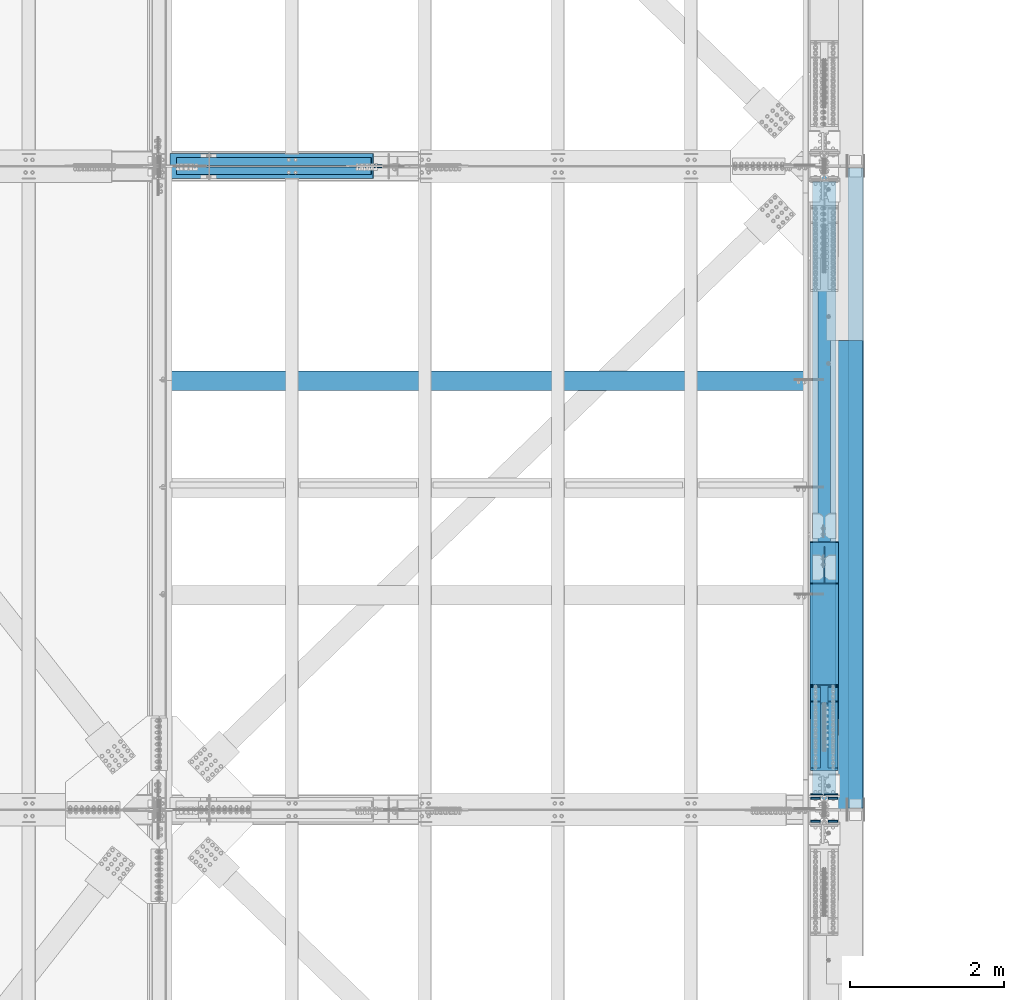
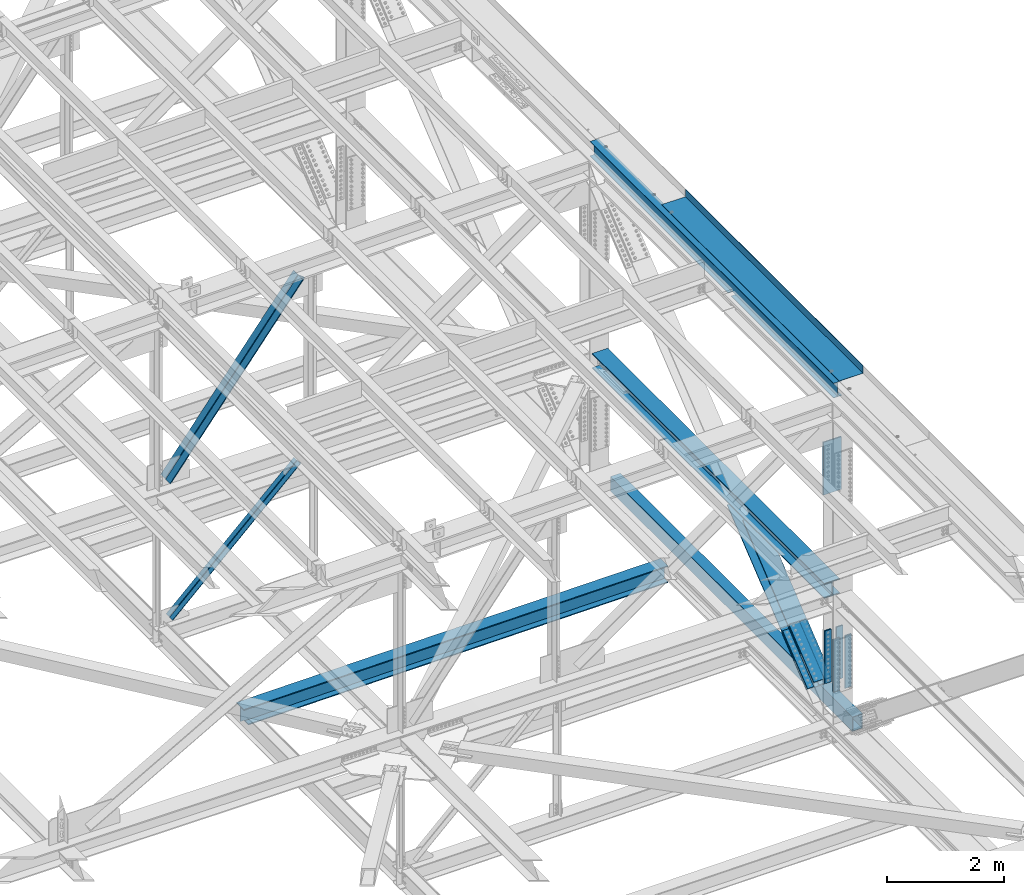
# One storey, part 1975 of 3843: 11 members, 10 beams, 11 elements without a shape of their own.
"""IFC2X3 building model written with IfcOpenShell, lengths in millimetres."""

from ifc_helpers import new_model, si_unit, frame, origin_with_axes, place, context, subcontext, project, spatial, faceted_brep, material, type_object, element, aggregate, save


model = new_model("IFC2X3")

# Units and contexts
model_context = context("Model", 3, precision=1e-05, world=origin_with_axes())
body_context = subcontext(model_context, "Body", "Model", "MODEL_VIEW")
ifc_project = project(units=[si_unit("LENGTHUNIT", "METRE", prefix="MILLI"), si_unit("AREAUNIT", "SQUARE_METRE"), si_unit("VOLUMEUNIT", "CUBIC_METRE"), si_unit("MASSUNIT", "GRAM", prefix="KILO"), si_unit("TIMEUNIT", "SECOND"), si_unit("PLANEANGLEUNIT", "RADIAN"), si_unit("SOLIDANGLEUNIT", "STERADIAN"), si_unit("THERMODYNAMICTEMPERATUREUNIT", "DEGREE_CELSIUS"), si_unit("LUMINOUSINTENSITYUNIT", "LUMEN")], contexts=[model_context])

# Site, building, storey
site_placement = place(None, origin_with_axes())
site = spatial("IfcSite", under=ifc_project, at=site_placement, CompositionType="ELEMENT")
building_placement = place(site_placement, origin_with_axes())
building = spatial("IfcBuilding", under=site, at=building_placement, Name="Undefined", CompositionType="ELEMENT")
storey_placement = place(building_placement, origin_with_axes())
storey = spatial("IfcBuildingStorey", under=building, at=storey_placement, Name="Undefined", CompositionType="ELEMENT", Elevation=0.0)

# Assembly, beam
assembly_1_placement = place(storey_placement, origin_with_axes())
assembly_1 = element("IfcElementAssembly", 1, at=assembly_1_placement, inside=storey, Name="BEAM", AssemblyPlace="NOTDEFINED", PredefinedType="RIGID_FRAME")
ifc_material_1 = material(Name="STEEL/A992")
beam_type_1 = type_object("IfcBeamType", Name="W12X26", PredefinedType="NOTDEFINED")
beam_1_placement = place(assembly_1_placement, frame((85648.8000000019, 58915.3, 46612.1749999999), z_axis=(0.0, 0.0, 1.0), x_axis=(0.0, 1.0, 0.0)))
beam_1 = element("IfcBeam", 2, at=beam_1_placement, type_object=beam_type_1, material=ifc_material_1, Name="BEAM", ObjectType="W12X26", context=body_context, shape_type="Brep", body=[
    faceted_brep([(3516.31250318501, -3.17500000000291, -146.050000000003), (3516.31250318501, -82.5500000000029, -146.050000000003), (3516.31250318501, -82.5500000000029, -155.574999999997), (3516.31250318501, 82.5500000000029, -155.574999999997), (3516.31250318501, 82.5500000000029, -146.050000000003), (3516.31250318501, 3.17500000000291, -146.050000000003), (3516.31250318501, 3.17500000000291, -139.699999999946), (3516.31250318501, -3.17500000000291, -139.699999999946), (3625.84999844209, -3.17500000000291, -139.699999999946), (3625.84999844209, 3.17500000000291, -139.699999999946), (3625.84999844209, 3.17500000000291, -146.050000000003), (3625.84999844209, 82.5500000000029, -146.050000000003), (3625.84999844209, 82.5500000000029, -155.574999999997), (3625.84999844209, -82.5500000000029, -155.574999999997), (3625.84999844209, -82.5500000000029, -146.050000000003), (3625.84999844209, -3.17500000000291, -146.050000000003), (0.0, -82.5500000000029, 155.574999999997), (0.0, -82.5500000000029, 146.050000000003), (8356.60000000001, -82.5500000000029, 146.050000000003), (8356.60000000001, -82.5500000000029, 155.574999999997), (0.0, 82.5500000000029, 155.574999999997), (8356.60000000001, 82.5500000000029, 155.574999999997), (0.0, 82.5500000000029, 146.050000000003), (8356.60000000001, 82.5500000000029, 146.050000000003), (0.0, 3.17500000000291, 146.050000000003), (8356.60000000001, 3.17500000000291, 146.050000000003), (0.0, -82.5500000000029, -155.574999999997), (0.0, -82.5500000000029, -146.050000000003), (0.0, -3.17500000000291, -146.050000000003), (0.0, -3.17500000000291, 146.050000000003), (0.0, 3.17500000000291, -146.050000000003), (0.0, 82.5500000000029, -146.050000000003), (0.0, 82.5500000000029, -155.574999999997), (8356.60000000001, -3.17500000000291, 146.050000000003), (8356.60000000001, 3.17500000000291, -146.050000000003), (8356.60000000001, -3.17500000000291, -146.050000000003), (8356.60000000001, -82.5500000000029, -146.050000000003), (8356.60000000001, -82.5500000000029, -155.574999999997), (8356.60000000001, 82.5500000000029, -155.574999999997), (8356.60000000001, 82.5500000000029, -146.050000000003)], [[[0, 1, 2, 3, 4, 5, 6, 7]], [[8, 9, 10, 11, 12, 13, 14, 15]], [[7, 6, 9, 8]], [[16, 17, 18, 19]], [[20, 16, 19, 21]], [[22, 20, 21, 23]], [[24, 22, 23, 25]], [[26, 27, 28, 29, 17, 16, 20, 22, 24, 30, 31, 32]], [[17, 29, 33, 18]], [[34, 25, 23, 21, 19, 18, 33, 35, 36, 37, 38, 39]], [[36, 35, 15, 14]], [[37, 36, 14, 13]], [[38, 37, 13, 12]], [[39, 38, 12, 11]], [[34, 39, 11, 10]], [[5, 30, 24, 25, 34, 10, 9, 6]], [[31, 30, 5, 4]], [[32, 31, 4, 3]], [[26, 32, 3, 2]], [[27, 26, 2, 1]], [[28, 27, 1, 0]], [[35, 33, 29, 28, 0, 7, 8, 15]]]),
])

# Assembly, member
assembly_2_placement = place(storey_placement, origin_with_axes())
assembly_2 = element("IfcElementAssembly", 3, at=assembly_2_placement, inside=storey, Name="ANGLE", AssemblyPlace="NOTDEFINED", PredefinedType="RIGID_FRAME")
ifc_material_2 = material(Name="STEEL/A572-50")
member_type_1 = type_object("IfcMemberType", Name="L4X4X3/8", PredefinedType="NOTDEFINED")
member_1_placement = place(assembly_2_placement, frame((80060.8000000188, 67332.225, 42332.0264524968), z_axis=(0.0, 1.0, 0.0), x_axis=(-0.72616110503847, 0.0, -0.687524581036423)))
member_1 = element("IfcMember", 4, at=member_1_placement, type_object=member_type_1, material=ifc_material_2, Name="ANGLE", ObjectType="L4X4X3/8", context=body_context, shape_type="Brep", body=[
    faceted_brep([(359.165116662829, 50.8000000007632, -50.8000000000029), (359.165116662829, 50.8000000007632, 50.8000000000029), (3843.58849766703, 50.8000000090506, 50.8000000000029), (3843.58849766703, 50.8000000090506, -50.8000000000029), (359.165116669756, 41.27500000078, 50.8000000000029), (3843.58849767395, 41.2750000090637, 50.8000000000029), (359.165116669756, 41.27500000078, -41.2749999999942), (3843.58849767395, 41.2750000090637, -41.2749999999942), (359.165116736607, -50.7999999990607, -41.2749999999942), (3843.58849774081, -50.7999999907806, -41.2749999999942), (359.165116736607, -50.7999999990607, -50.8000000000029), (3843.58849774081, -50.7999999907806, -50.8000000000029)], [[[0, 1, 2, 3]], [[1, 4, 5, 2]], [[4, 6, 7, 5]], [[6, 8, 9, 7]], [[8, 10, 11, 9]], [[10, 0, 3, 11]], [[5, 7, 9, 11, 3, 2]], [[10, 8, 6, 4, 1, 0]]]),
])
aggregate(assembly_2, [member_1])

assembly_3_placement = place(storey_placement, origin_with_axes())
assembly_3 = element("IfcElementAssembly", 5, at=assembly_3_placement, inside=storey, Name="ANGLE", AssemblyPlace="NOTDEFINED", PredefinedType="RIGID_FRAME")
member_2_placement = place(assembly_3_placement, frame((77012.8000000054, 67211.575, 39446.2000000013), z_axis=(0.0, -1.0, 0.0), x_axis=(0.726161105038472, 0.0, 0.68752458103642)))
member_2 = element("IfcMember", 6, at=member_2_placement, type_object=member_type_1, material=ifc_material_2, Name="ANGLE", ObjectType="L4X4X3/8", context=body_context, shape_type="Brep", body=[
    faceted_brep([(353.827173144615, 50.8000000012835, -50.8000000000029), (353.827173144615, 50.8000000012835, 50.8000000000029), (3838.25055414259, 50.800000012463, 50.8000000000029), (3838.25055414259, 50.800000012463, -50.8000000000029), (353.827173144557, 41.2750000012566, 50.8000000000029), (3838.25055414255, 41.2750000124361, 50.8000000000029), (353.827173144557, 41.2750000012566, -41.2749999999942), (3838.25055414255, 41.2750000124361, -41.2749999999942), (353.827173144105, -50.7999999989916, -41.2749999999942), (3838.25055414208, -50.799999987812, -41.2749999999942), (353.827173144105, -50.7999999989916, -50.8000000000029), (3838.25055414208, -50.799999987812, -50.8000000000029)], [[[0, 1, 2, 3]], [[1, 4, 5, 2]], [[4, 6, 7, 5]], [[6, 8, 9, 7]], [[8, 10, 11, 9]], [[10, 0, 3, 11]], [[5, 7, 9, 11, 3, 2]], [[10, 8, 6, 4, 1, 0]]]),
])
aggregate(assembly_3, [member_2])

# Assembly, beam
assembly_4_placement = place(storey_placement, origin_with_axes())
assembly_4 = element("IfcElementAssembly", 7, at=assembly_4_placement, inside=storey, Name="BEAM", AssemblyPlace="NOTDEFINED", PredefinedType="RIGID_FRAME")
ifc_material_3 = material()
beam_type_2 = type_object("IfcBeamType", Name="HSS12X8X3/8", PredefinedType="NOTDEFINED")
beam_2_placement = place(assembly_4_placement, frame((86055.2000000001, 67246.5, 39477.9499999175), z_axis=(0.0, 0.0, 1.0), x_axis=(0.0, -1.0, 0.0)))
beam_2 = element("IfcBeam", 8, at=beam_2_placement, type_object=beam_type_2, material=ifc_material_3, Name="BEAM", ObjectType="HSS12X8X3/8", context=body_context, shape_type="Brep", body=[
    faceted_brep([(0.0, 92.0749999999971, -142.875), (0.0, -92.0749999999971, -142.875), (8305.80000000002, -92.0749999999971, -142.875), (8305.80000000002, 92.0749999999971, -142.875), (0.0, -92.0749999999971, 142.875), (8305.80000000002, -92.0749999999971, 142.875), (0.0, 92.0749999999971, 142.875), (8305.80000000002, 92.0749999999971, 142.875), (0.0, 101.600000000006, -152.400000000001), (0.0, 101.600000000006, 152.400000000001), (8305.80000000002, 101.600000000006, 152.400000000001), (8305.80000000002, 101.600000000006, -152.400000000001), (0.0, -101.600000000006, 152.400000000001), (8305.80000000002, -101.600000000006, 152.400000000001), (0.0, -101.600000000006, -152.400000000001), (8305.80000000002, -101.600000000006, -152.400000000001)], [[[0, 1, 2, 3]], [[1, 4, 5, 2]], [[4, 6, 7, 5]], [[6, 0, 3, 7]], [[8, 9, 10, 11]], [[9, 12, 13, 10]], [[12, 14, 15, 13]], [[14, 8, 11, 15]], [[13, 15, 11, 10], [5, 7, 3, 2]], [[14, 12, 9, 8], [6, 4, 1, 0]]]),
])
aggregate(assembly_4, [beam_2])

# Assembly, members
assembly_5_placement = place(storey_placement, origin_with_axes())
assembly_5 = element("IfcElementAssembly", 9, at=assembly_5_placement, inside=storey, Name="BEAM", AssemblyPlace="NOTDEFINED", PredefinedType="RIGID_FRAME")
member_type_2 = type_object("IfcMemberType", PredefinedType="NOTDEFINED")
member_3_placement = place(assembly_5_placement, frame((85763.1, 59649.7599619214, 39957.4534432185), z_axis=(-1.0, 0.0, 0.0), x_axis=(0.0, 0.77717665715686, 0.629282483127005)))
member_3 = element("IfcMember", 10, at=member_3_placement, type_object=member_type_2, material=ifc_material_2, Name="PLATE", context=body_context, shape_type="Brep", body=[
    faceted_brep([(-4.36557456851006e-11, 12.7000000000116, -63.5), (-4.36557456851006e-11, 12.7000000000116, 63.5), (1104.90000001677, 12.7000000017251, 63.5), (1104.90000001677, 12.7000000017251, -63.5), (1.45519152283669e-11, -12.700000000008, 63.5), (1104.90000001682, -12.6999999982909, 63.5), (1.45519152283669e-11, -12.700000000008, -63.5), (1104.90000001682, -12.6999999982909, -63.5)], [[[0, 1, 2, 3]], [[1, 4, 5, 2]], [[4, 6, 7, 5]], [[6, 0, 3, 7]], [[5, 7, 3, 2]], [[6, 4, 1, 0]]]),
])
member_4_placement = place(assembly_5_placement, frame((85763.1, 59464.0661578307, 40186.789064572), z_axis=(-1.0, 0.0, 0.0), x_axis=(0.0, 0.77717665715686, 0.629282483127005)))
member_4 = element("IfcMember", 11, at=member_4_placement, type_object=member_type_2, material=ifc_material_2, Name="PLATE", context=body_context, shape_type="Brep", body=[
    faceted_brep([(-4.36557456851006e-11, 12.7000000000116, -63.5), (-4.36557456851006e-11, 12.7000000000116, 63.5), (1104.90000001677, 12.7000000017251, 63.5), (1104.90000001677, 12.7000000017251, -63.5), (1.45519152283669e-11, -12.700000000008, 63.5), (1104.90000001682, -12.6999999982909, 63.5), (1.45519152283669e-11, -12.700000000008, -63.5), (1104.90000001682, -12.6999999982909, -63.5)], [[[0, 1, 2, 3]], [[1, 4, 5, 2]], [[4, 6, 7, 5]], [[6, 0, 3, 7]], [[5, 7, 3, 2]], [[6, 4, 1, 0]]]),
])
member_5_placement = place(assembly_5_placement, frame((85534.5, 59649.7599619214, 39957.4534432185), z_axis=(-1.0, 0.0, 0.0), x_axis=(0.0, 0.77717665715686, 0.629282483127005)))
member_5 = element("IfcMember", 12, at=member_5_placement, type_object=member_type_2, material=ifc_material_2, Name="PLATE", context=body_context, shape_type="Brep", body=[
    faceted_brep([(-4.36557456851006e-11, 12.7000000000116, -63.5), (-4.36557456851006e-11, 12.7000000000116, 63.5), (1104.90000001677, 12.7000000017251, 63.5), (1104.90000001677, 12.7000000017251, -63.5), (1.45519152283669e-11, -12.700000000008, 63.5), (1104.90000001682, -12.6999999982909, 63.5), (1.45519152283669e-11, -12.700000000008, -63.5), (1104.90000001682, -12.6999999982909, -63.5)], [[[0, 1, 2, 3]], [[1, 4, 5, 2]], [[4, 6, 7, 5]], [[6, 0, 3, 7]], [[5, 7, 3, 2]], [[6, 4, 1, 0]]]),
])
member_6_placement = place(assembly_5_placement, frame((85534.5, 59464.0661578307, 40186.789064572), z_axis=(-1.0, 0.0, 0.0), x_axis=(0.0, 0.77717665715686, 0.629282483127005)))
member_6 = element("IfcMember", 13, at=member_6_placement, type_object=member_type_2, material=ifc_material_2, Name="PLATE", context=body_context, shape_type="Brep", body=[
    faceted_brep([(-4.36557456851006e-11, 12.7000000000116, -63.5), (-4.36557456851006e-11, 12.7000000000116, 63.5), (1104.90000001677, 12.7000000017251, 63.5), (1104.90000001677, 12.7000000017251, -63.5), (1.45519152283669e-11, -12.700000000008, 63.5), (1104.90000001682, -12.6999999982909, 63.5), (1.45519152283669e-11, -12.700000000008, -63.5), (1104.90000001682, -12.6999999982909, -63.5)], [[[0, 1, 2, 3]], [[1, 4, 5, 2]], [[4, 6, 7, 5]], [[6, 0, 3, 7]], [[5, 7, 3, 2]], [[6, 4, 1, 0]]]),
])
member_type_3 = type_object("IfcMemberType", PredefinedType="NOTDEFINED")
member_7_placement = place(assembly_5_placement, frame((85648.8, 60294.5855000221, 40916.8900385405), z_axis=(-1.0, 0.0, 0.0), x_axis=(0.0, -0.77717665715686, -0.629282483127005)))
member_7 = element("IfcMember", 14, at=member_7_placement, type_object=member_type_3, material=ifc_material_2, Name="PLATE", context=body_context, shape_type="Brep", body=[
    faceted_brep([(-1.45519152283669e-11, 12.7000000000025, -177.800000000003), (-1.45519152283669e-11, 12.7000000000025, 177.800000000003), (1104.90000001682, 12.7000000017051, 177.800000000003), (1104.90000001682, 12.7000000017051, -177.800000000003), (4.36557456851006e-11, -12.7000000000171, 177.800000000003), (1104.90000001686, -12.6999999983072, 177.800000000003), (4.36557456851006e-11, -12.7000000000171, -177.800000000003), (1104.90000001686, -12.6999999983072, -177.800000000003)], [[[0, 1, 2, 3]], [[1, 4, 5, 2]], [[4, 6, 7, 5]], [[6, 0, 3, 7]], [[5, 7, 3, 2]], [[6, 4, 1, 0]]]),
])
member_8_placement = place(assembly_5_placement, frame((85648.8, 60536.5516369621, 40618.0569426632), z_axis=(-1.0, 0.0, 0.0), x_axis=(0.0, -0.77717665715686, -0.629282483127005)))
member_8 = element("IfcMember", 15, at=member_8_placement, type_object=member_type_3, material=ifc_material_2, Name="PLATE", context=body_context, shape_type="Brep", body=[
    faceted_brep([(-1.45519152283669e-11, 12.7000000000025, -177.800000000003), (-1.45519152283669e-11, 12.7000000000025, 177.800000000003), (1104.90000001682, 12.7000000017051, 177.800000000003), (1104.90000001682, 12.7000000017051, -177.800000000003), (4.36557456851006e-11, -12.7000000000171, 177.800000000003), (1104.90000001686, -12.6999999983072, 177.800000000003), (4.36557456851006e-11, -12.7000000000171, -177.800000000003), (1104.90000001686, -12.6999999983072, -177.800000000003)], [[[0, 1, 2, 3]], [[1, 4, 5, 2]], [[4, 6, 7, 5]], [[6, 0, 3, 7]], [[5, 7, 3, 2]], [[6, 4, 1, 0]]]),
])

# Assembly, member
assembly_6_placement = place(storey_placement, origin_with_axes())
assembly_6 = element("IfcElementAssembly", 16, at=assembly_6_placement, inside=storey, Name="V. BRACE", AssemblyPlace="NOTDEFINED", PredefinedType="RIGID_FRAME")
member_type_4 = type_object("IfcMemberType", Name="W14X99", PredefinedType="NOTDEFINED")
member_9_placement = place(assembly_6_placement, frame((85648.8, 59986.3230941713, 40419.6957547924), z_axis=(0.0, -0.62928248312701, 0.777176657156856), x_axis=(0.0, 0.77717665715686, 0.629282483127005)))
member_9 = element("IfcMember", 17, at=member_9_placement, type_object=member_type_4, material=ifc_material_1, Name="V. BRACE", ObjectType="W14X99", context=body_context, shape_type="Brep", body=[
    faceted_brep([(2542.53010692944, -185.737500000003, 179.387499988941), (2542.52424842126, -185.737500000003, 160.485612199787), (2542.52424842126, 185.737500000003, 160.485612199787), (2542.53010692944, 185.737500000003, 179.387499988941), (6.35000000674336, -185.737500000003, -179.387500001117), (6.35000000674336, 185.737500000003, -179.387500001117), (2960.83732776028, 185.737500000003, -179.387500012799), (2960.83732776028, -185.737500000003, -179.387500012799), (6.35000000674336, -185.737500000003, -160.33750000099), (2960.84323225524, -185.737500000003, -160.337500012796), (6.35000000674336, -6.35000000000582, -160.33750000099), (2960.84323225524, -6.35000000000582, -160.337500012796), (6.35000000639411, -185.737500000003, 160.337500001014), (6.35000000639411, -6.35000000000582, 160.337500001014), (2491.5982520728, -6.35000000000582, 160.337499989168), (2491.5982520728, -185.737500000003, 160.337499989168), (2893.84041877068, -6.35000000000582, -122.198289454835), (2913.99076988701, 6.35000000000582, -122.20453489069), (2612.91216471013, 6.35000000000582, 122.363794065139), (2592.76181334526, -6.35000000000582, 122.370039554309), (6.35000000674336, 185.737500000003, -160.33750000099), (6.35000000674336, 6.35000000000582, -160.33750000099), (2960.84323225524, 6.35000000000582, -160.337500012796), (2960.84323225524, 185.737500000003, -160.337500012796), (2868.1534748288, 6.35000000000582, -122.190327997505), (2862.65391000066, 6.35000000000582, -123.936325468258), (2859.17144562426, 6.35000000000582, -128.536995238395), (2858.98404704587, 6.35000000000582, -134.30402239626), (2862.16048421207, 6.35000000000582, -139.121072053036), (2888.34069326254, 6.35000000000582, -160.296586512137), (2960.84325110541, 6.35000000000582, -160.276682631262), (6.35000000639411, 6.35000000000582, 160.337500001014), (2491.5982520728, 6.35000000000582, 160.337499989168), (2474.21847648415, 6.35000000000582, 137.735615845126), (2472.29089235618, 6.35000000000582, 132.871056566153), (2473.22371804006, 6.35000000000582, 127.722333055161), (2476.73544189859, 6.35000000000582, 123.843246424207), (2481.766282721, 6.35000000000582, 122.404442000818), (6.35000000639411, 185.737500000003, 160.337500001014), (2491.5982520728, 185.737500000003, 160.337499989168), (2474.21847648415, -6.35000000000582, 137.735615845126), (2491.72425065133, 185.737500000003, 160.501357414141), (2491.72425065133, -185.737500000003, 160.501357414141), (2472.29089235618, -6.35000000000582, 132.871056566153), (2473.22371804006, -6.35000000000582, 127.722333055161), (2476.73544189859, -6.35000000000582, 123.843246424207), (2481.766282721, -6.35000000000582, 122.404442000818), (2960.84325110541, -6.35000000000582, -160.276682631262), (2888.34069326254, -6.35000000000582, -160.296586512137), (2862.16048421207, -6.35000000000582, -139.121072053036), (2858.98404704587, -6.35000000000582, -134.30402239626), (2859.17144562426, -6.35000000000582, -128.536995238395), (2862.65391000066, -6.35000000000582, -123.936325468258), (2868.1534748288, -6.35000000000582, -122.190327997505), (6.35000000636501, -185.737500000003, 179.387500001133), (6.35000000636501, 185.737500000003, 179.387500001133)], [[[0, 1, 2, 3]], [[4, 5, 6, 7]], [[8, 4, 7, 9]], [[10, 8, 9, 11]], [[12, 13, 14, 15]], [[16, 17, 18, 19]], [[20, 21, 22, 23]], [[17, 24, 25, 26, 27, 28, 29, 30, 22, 21, 31, 32, 33, 34, 35, 36, 37, 18]], [[31, 38, 39, 32]], [[15, 14, 40, 33, 32, 39, 41, 42]], [[43, 34, 33, 40]], [[44, 35, 34, 43]], [[45, 36, 35, 44]], [[46, 37, 36, 45]], [[18, 37, 46, 19]], [[45, 44, 43, 40, 14, 13, 10, 11, 47, 48, 49, 50, 51, 52, 53, 16, 19, 46]], [[17, 16, 53, 24]], [[52, 25, 24, 53]], [[51, 26, 25, 52]], [[50, 27, 26, 51]], [[49, 28, 27, 50]], [[48, 29, 28, 49]], [[47, 30, 29, 48]], [[11, 9, 7, 6, 23, 22, 30, 47]], [[5, 20, 23, 6]], [[4, 8, 10, 13, 12, 54, 55, 38, 31, 21, 20, 5]], [[55, 54, 0, 3]], [[41, 39, 38, 55, 3, 2]], [[42, 41, 2, 1]], [[54, 12, 15, 42, 1, 0]]]),
])
aggregate(assembly_6, [member_9])

# Beam
beam_type_3 = type_object("IfcBeamType", PredefinedType="NOTDEFINED")
beam_3_placement = place(assembly_5_placement, frame((85763.1, 58767.6626841065, 41532.1793646476), z_axis=(-1.0, 0.0, 0.0), x_axis=(0.0, 0.0, -1.0)))
beam_3 = element("IfcBeam", 18, at=beam_3_placement, type_object=beam_type_3, material=ifc_material_2, Name="PLATE", context=body_context, shape_type="Brep", body=[
    faceted_brep([(-4.36557456851006e-11, 12.7000000000116, -63.5), (-4.36557456851006e-11, 12.7000000000116, 63.5), (1104.90000001677, 12.7000000017251, 63.5), (1104.90000001677, 12.7000000017251, -63.5), (1.45519152283669e-11, -12.700000000008, 63.5), (1104.90000001682, -12.6999999982909, 63.5), (1.45519152283669e-11, -12.700000000008, -63.5), (1104.90000001682, -12.6999999982909, -63.5)], [[[0, 1, 2, 3]], [[1, 4, 5, 2]], [[4, 6, 7, 5]], [[6, 0, 3, 7]], [[5, 7, 3, 2]], [[6, 4, 1, 0]]]),
])

beam_4_placement = place(assembly_5_placement, frame((85763.1, 59062.9376140281, 41532.1793371867), z_axis=(-1.0, 0.0, 0.0), x_axis=(0.0, 0.0, -1.0)))
beam_4 = element("IfcBeam", 19, at=beam_4_placement, type_object=beam_type_3, material=ifc_material_2, Name="PLATE", context=body_context, shape_type="Brep", body=[
    faceted_brep([(-4.36557456851006e-11, 12.7000000000116, -63.5), (-4.36557456851006e-11, 12.7000000000116, 63.5), (1104.90000001677, 12.7000000017251, 63.5), (1104.90000001677, 12.7000000017251, -63.5), (1.45519152283669e-11, -12.700000000008, 63.5), (1104.90000001682, -12.6999999982909, 63.5), (1.45519152283669e-11, -12.700000000008, -63.5), (1104.90000001682, -12.6999999982909, -63.5)], [[[0, 1, 2, 3]], [[1, 4, 5, 2]], [[4, 6, 7, 5]], [[6, 0, 3, 7]], [[5, 7, 3, 2]], [[6, 4, 1, 0]]]),
])

beam_5_placement = place(assembly_5_placement, frame((85534.5, 58767.6626841065, 41532.1793646476), z_axis=(-1.0, 0.0, 0.0), x_axis=(0.0, 0.0, -1.0)))
beam_5 = element("IfcBeam", 20, at=beam_5_placement, type_object=beam_type_3, material=ifc_material_2, Name="PLATE", context=body_context, shape_type="Brep", body=[
    faceted_brep([(-4.36557456851006e-11, 12.7000000000116, -63.5), (-4.36557456851006e-11, 12.7000000000116, 63.5), (1104.90000001677, 12.7000000017251, 63.5), (1104.90000001677, 12.7000000017251, -63.5), (1.45519152283669e-11, -12.700000000008, 63.5), (1104.90000001682, -12.6999999982909, 63.5), (1.45519152283669e-11, -12.700000000008, -63.5), (1104.90000001682, -12.6999999982909, -63.5)], [[[0, 1, 2, 3]], [[1, 4, 5, 2]], [[4, 6, 7, 5]], [[6, 0, 3, 7]], [[5, 7, 3, 2]], [[6, 4, 1, 0]]]),
])

beam_6_placement = place(assembly_5_placement, frame((85534.5, 59062.9376140281, 41532.1793371867), z_axis=(-1.0, 0.0, 0.0), x_axis=(0.0, 0.0, -1.0)))
beam_6 = element("IfcBeam", 21, at=beam_6_placement, type_object=beam_type_3, material=ifc_material_2, Name="PLATE", context=body_context, shape_type="Brep", body=[
    faceted_brep([(-4.36557456851006e-11, 12.7000000000116, -63.5), (-4.36557456851006e-11, 12.7000000000116, 63.5), (1104.90000001677, 12.7000000017251, 63.5), (1104.90000001677, 12.7000000017251, -63.5), (1.45519152283669e-11, -12.700000000008, 63.5), (1104.90000001682, -12.6999999982909, 63.5), (1.45519152283669e-11, -12.700000000008, -63.5), (1104.90000001682, -12.6999999982909, -63.5)], [[[0, 1, 2, 3]], [[1, 4, 5, 2]], [[4, 6, 7, 5]], [[6, 0, 3, 7]], [[5, 7, 3, 2]], [[6, 4, 1, 0]]]),
])

aggregate(assembly_5, [member_3, member_4, member_5, member_7, member_8, member_6, beam_3, beam_4, beam_5, beam_6])

# Assembly, beam
assembly_7_placement = place(storey_placement, origin_with_axes())
assembly_7 = element("IfcElementAssembly", 22, at=assembly_7_placement, inside=storey, Name="BEAM", AssemblyPlace="NOTDEFINED", PredefinedType="RIGID_FRAME")
beam_type_4 = type_object("IfcBeamType", PredefinedType="NOTDEFINED")
beam_7_placement = place(assembly_7_placement, frame((85648.8, 59113.7375706862, 45450.1298129965), z_axis=(1.0, 0.0, 0.0), x_axis=(0.0, 0.0, -1.0)))
beam_7 = element("IfcBeam", 23, at=beam_7_placement, type_object=beam_type_4, material=ifc_material_2, Name="PLATE", context=body_context, shape_type="Brep", body=[
    faceted_brep([(-1.45519152283669e-11, 12.7000000000025, -177.800000000003), (-1.45519152283669e-11, 12.7000000000025, 177.800000000003), (1104.90000001682, 12.7000000017051, 177.800000000003), (1104.90000001682, 12.7000000017051, -177.800000000003), (4.36557456851006e-11, -12.7000000000171, 177.800000000003), (1104.90000001686, -12.6999999983072, 177.800000000003), (4.36557456851006e-11, -12.7000000000171, -177.800000000003), (1104.90000001686, -12.6999999983072, -177.800000000003)], [[[0, 1, 2, 3]], [[1, 4, 5, 2]], [[4, 6, 7, 5]], [[6, 0, 3, 7]], [[5, 7, 3, 2]], [[6, 4, 1, 0]]]),
])
aggregate(assembly_7, [beam_7])

assembly_8_placement = place(storey_placement, origin_with_axes())
assembly_8 = element("IfcElementAssembly", 24, at=assembly_8_placement, inside=storey, Name="BEAM", AssemblyPlace="NOTDEFINED", PredefinedType="RIGID_FRAME")
beam_type_5 = type_object("IfcBeamType", Name="W12X87", PredefinedType="NOTDEFINED")
beam_8_placement = place(assembly_8_placement, frame((85648.8, 58914.8099646019, 42322.7473701367), z_axis=(0.0, 0.00069807800023409, 0.999999756343523), x_axis=(0.0, 0.999999756343523, -0.000698078000240817)))
beam_8 = element("IfcBeam", 25, at=beam_8_placement, type_object=beam_type_5, material=ifc_material_1, Name="BEAM", ObjectType="W12X87", context=body_context, shape_type="Brep", body=[
    faceted_brep([(199.038502796793, -153.987500000003, -158.75000000016), (199.038502796793, 153.987500000003, -158.75000000016), (8158.76544006648, 153.987500000003, -158.750000012056), (8158.76544006648, -153.987500000003, -158.750000012056), (199.024095610061, -153.987500000003, -138.112500000185), (199.024095610061, -6.35000000000582, -138.112500000185), (198.83126095694, -6.35000000000582, 138.112499999603), (198.83126095694, -153.987500000003, 138.112499999603), (198.816853770215, -153.987500000003, 158.749999999585), (198.816853770215, 153.987500000003, 158.749999999585), (198.83126095694, 153.987500000003, 138.112499999603), (198.83126095694, 6.35000000000582, 138.112499999603), (199.024095610061, 6.35000000000582, -138.112500000185), (199.024095610061, 153.987500000003, -138.112500000185), (8158.75103275594, -153.987500000003, -138.112500012074), (8158.75103275594, -6.35000000000582, -138.112500012074), (8158.55819644547, -6.35000000000582, 138.112499987714), (8158.55819644547, -153.987500000003, 138.112499987714), (8158.54378913492, -153.987500000003, 158.749999987696), (8158.54378913492, 153.987500000003, 158.749999987696), (8158.55819644547, 153.987500000003, 138.112499987714), (8158.55819644547, 6.35000000000582, 138.112499987714), (8158.75103275594, 6.35000000000582, -138.112500012074), (8158.75103275594, 153.987500000003, -138.112500012074)], [[[0, 1, 2, 3]], [[0, 4, 5, 6, 7, 8, 9, 10, 11, 12, 13, 1]], [[5, 4, 14, 15]], [[6, 5, 15, 16]], [[7, 6, 16, 17]], [[8, 7, 17, 18]], [[9, 8, 18, 19]], [[10, 9, 19, 20]], [[11, 10, 20, 21]], [[12, 11, 21, 22]], [[13, 12, 22, 23]], [[1, 13, 23, 2]], [[22, 21, 20, 19, 18, 17, 16, 15, 14, 3, 2, 23]], [[4, 0, 3, 14]]]),
])
aggregate(assembly_8, [beam_8])

# Beam
ifc_material_4 = material(Name="STEEL/A36")
beam_type_6 = type_object("IfcBeamType", PredefinedType="NOTDEFINED")
beam_9_placement = place(assembly_1_placement, frame((85680.5500000019, 61963.3, 46772.5124999999), z_axis=(0.0, -1.0, 0.0), x_axis=(1.0, 0.0, 0.0)))
beam_9 = element("IfcBeam", 26, at=beam_9_placement, type_object=beam_type_6, material=ifc_material_4, Name="BENT_PLATE", context=body_context, shape_type="Brep", body=[
    faceted_brep([(466.724998474107, 4.76249999999709, -3044.82500004767), (469.899999921181, 1.58750004768081, -3048.0), (0.0, 1.58750004768081, -3048.0), (0.0, 4.76249999999709, -3044.82500004768), (466.725000000006, 160.337499999994, -3044.82500004767), (469.900001478221, 160.337499968853, -3048.0), (0.0, 4.76249999999709, 3048.0), (466.724998474107, 4.76249999999709, 3048.0), (0.0, -4.76249999999709, -3048.0), (0.0, -4.76249999999709, 3048.0), (476.249998380677, -4.76249999999709, -3048.0), (476.249998380677, -4.76249999999709, 3048.0), (466.725000000006, 160.337499999994, 3048.0), (476.25, 160.337499906571, 3048.0), (476.25, 160.337499906571, -3048.0)], [[[0, 1, 2, 3]], [[4, 5, 1, 0]], [[6, 7, 0, 3]], [[8, 9, 6, 3, 2]], [[9, 8, 10, 11]], [[7, 12, 4, 0]], [[7, 6, 9, 11, 13, 12]], [[11, 10, 14, 13]], [[5, 14, 10, 8, 2, 1]], [[12, 13, 14, 5, 4]]]),
])

aggregate(assembly_1, [beam_9, beam_1])

# Assembly, member
assembly_9_placement = place(storey_placement, origin_with_axes())
assembly_9 = element("IfcElementAssembly", 27, at=assembly_9_placement, inside=storey, Name="ANGLE", AssemblyPlace="NOTDEFINED", PredefinedType="RIGID_FRAME")
member_type_5 = type_object("IfcMemberType", Name="L6X6X1/2", PredefinedType="NOTDEFINED")
member_10_placement = place(assembly_9_placement, frame((80060.800000138, 67357.625, 46226.8738706244), z_axis=(0.0, 1.0, 0.0), x_axis=(-0.616853737850191, 0.0, -0.787077801808848)))
member_10 = element("IfcMember", 28, at=member_10_placement, type_object=member_type_5, material=ifc_material_2, Name="ANGLE", ObjectType="L6X6X1/2", context=body_context, shape_type="Brep", body=[
    faceted_brep([(348.082680071719, 76.2000000006083, -76.1999999999971), (348.082680071719, 76.2000000006083, 76.1999999999971), (4613.78216639382, 76.2000000080516, 76.1999999999971), (4613.78216639382, 76.2000000080516, -76.1999999999971), (348.082680071646, 63.5000000006039, 76.1999999999971), (4613.78216639374, 63.5000000080327, 76.1999999999971), (348.082680071646, 63.5000000006039, -63.5), (4613.78216639374, 63.5000000080327, -63.5), (348.082680070831, -76.199999999415, -63.5), (4613.78216639295, -76.199999991979, -63.5), (348.082680070831, -76.199999999415, -76.1999999999971), (4613.78216639295, -76.199999991979, -76.1999999999971)], [[[0, 1, 2, 3]], [[1, 4, 5, 2]], [[4, 6, 7, 5]], [[6, 8, 9, 7]], [[8, 10, 11, 9]], [[10, 0, 3, 11]], [[5, 7, 9, 11, 3, 2]], [[10, 8, 6, 4, 1, 0]]]),
])
aggregate(assembly_9, [member_10])

assembly_10_placement = place(storey_placement, origin_with_axes())
assembly_10 = element("IfcElementAssembly", 29, at=assembly_10_placement, inside=storey, Name="ANGLE", AssemblyPlace="NOTDEFINED", PredefinedType="RIGID_FRAME")
member_11_placement = place(assembly_10_placement, frame((77012.8000007684, 67186.175, 42337.7620891929), z_axis=(0.0, -1.0, 0.0), x_axis=(0.616853737850189, 0.0, 0.787077801808849)))
member_11 = element("IfcMember", 30, at=member_11_placement, type_object=member_type_5, material=ifc_material_2, Name="ANGLE", ObjectType="L6X6X1/2", context=body_context, shape_type="Brep", body=[
    faceted_brep([(327.421578148147, 76.1999999994368, -76.1999999999971), (327.421578148147, 76.1999999994368, 76.1999999999971), (4593.12106447024, 76.1999999920008, 76.1999999999971), (4593.12106447024, 76.1999999920008, -76.1999999999971), (327.421578148205, 63.4999999994325, 76.1999999999971), (4593.12106447032, 63.4999999919892, 76.1999999999971), (327.421578148205, 63.4999999994325, -63.5), (4593.12106447032, 63.4999999919892, -63.5), (327.42157814902, -76.2000000005864, -63.5), (4593.12106447111, -76.2000000080297, -63.5), (327.42157814902, -76.2000000005864, -76.1999999999971), (4593.12106447111, -76.2000000080297, -76.1999999999971)], [[[0, 1, 2, 3]], [[1, 4, 5, 2]], [[4, 6, 7, 5]], [[6, 8, 9, 7]], [[8, 10, 11, 9]], [[10, 0, 3, 11]], [[5, 7, 9, 11, 3, 2]], [[10, 8, 6, 4, 1, 0]]]),
])
aggregate(assembly_10, [member_11])

# Assembly, beam
assembly_11_placement = place(storey_placement, origin_with_axes())
assembly_11 = element("IfcElementAssembly", 31, at=assembly_11_placement, inside=storey, Name="BEAM", AssemblyPlace="NOTDEFINED", PredefinedType="RIGID_FRAME")
beam_type_7 = type_object("IfcBeamType", Name="W14X68", PredefinedType="NOTDEFINED")
beam_10_placement = place(assembly_11_placement, frame((77011.2863734203, 64485.639068, 39446.1935570671), z_axis=(-0.00851308500030426, 0.0, 0.99996376303533), x_axis=(0.99996376303533, 0.0, 0.00851308500030053)))
beam_10 = element("IfcBeam", 32, at=beam_10_placement, type_object=beam_type_7, material=ifc_material_1, Name="BEAM", ObjectType="W14X68", context=body_context, shape_type="Brep", body=[
    faceted_brep([(18.5272118865687, -5.55625000000146, -146.049999995361), (18.5272118865687, 5.55625000000146, -146.049999995361), (94.4569118349318, 5.55625000000146, -146.049999997376), (94.4569118349318, -5.55625000000146, -146.049999997376), (99.3169913531019, 5.55625000000146, -147.016729919989), (99.3169913531019, -5.55625000000146, -147.016729919989), (103.437167821379, 5.55625000000146, -149.769743820485), (103.437167821379, -5.55625000000146, -149.769743820485), (106.190181721948, 5.55625000000146, -153.889920288661), (106.190181721948, -5.55625000000146, -153.889920288661), (107.15691164459, 5.55625000000146, -158.749999999636), (107.15691164459, -5.55625000000146, -158.749999999636), (107.156911644604, -127.0, -158.749999806714), (107.15691164459, 127.0, -158.749999999636), (107.15691164443, 127.0, -177.799999999566), (107.15691164443, -127.0, -177.799999999566), (21.1220942230721, 5.55625000000146, 158.749999999396), (21.1220942230721, 127.0, 158.749999999396), (8423.27031263262, 127.0, 158.749999983265), (8423.27031263262, 5.55625000000146, 158.749999983265), (21.2842743691144, 127.0, 177.799999999326), (8423.43249277867, 127.0, 177.799999983203), (21.2842743691144, -127.0, 177.799999999326), (8423.43249277867, -127.0, 177.799999983203), (21.1220942230721, -127.0, 158.749999999396), (8423.27031263262, -127.0, 158.749999983265), (21.1220942230721, -5.55625000000146, 158.749999999396), (8423.27031263262, -5.55625000000146, 158.749999983265), (8420.56731019873, 5.55625000000146, -158.750000015585), (8420.56731019873, -5.55625000000146, -158.750000015585), (8420.56731019873, -127.0, -158.750000015585), (8420.40513005269, -127.0, -177.800000015523), (8420.40513005269, 127.0, -177.800000015523), (8420.56731019873, 127.0, -158.750000015585), (18.8909659154015, 5.55625000000146, -103.322733934961), (20.8540833147999, 5.55625000000146, 127.268909819315)], [[[0, 1, 2, 3]], [[3, 2, 4, 5]], [[5, 4, 6, 7]], [[7, 6, 8, 9]], [[9, 8, 10, 11]], [[12, 11, 10, 13, 14, 15]], [[16, 17, 18, 19]], [[17, 20, 21, 18]], [[20, 22, 23, 21]], [[22, 24, 25, 23]], [[24, 26, 27, 25]], [[28, 19, 18, 21, 23, 25, 27, 29, 30, 31, 32, 33]], [[31, 30, 12, 15]], [[32, 31, 15, 14]], [[33, 32, 14, 13]], [[28, 33, 13, 10]], [[6, 4, 2, 1, 34, 35, 16, 19, 28, 10, 8]], [[26, 24, 22, 20, 17, 16, 35, 34, 1, 0]], [[29, 27, 26, 0, 3, 5, 7, 9, 11]], [[30, 29, 11, 12]]]),
])
aggregate(assembly_11, [beam_10])

save(model, "model.ifc")
